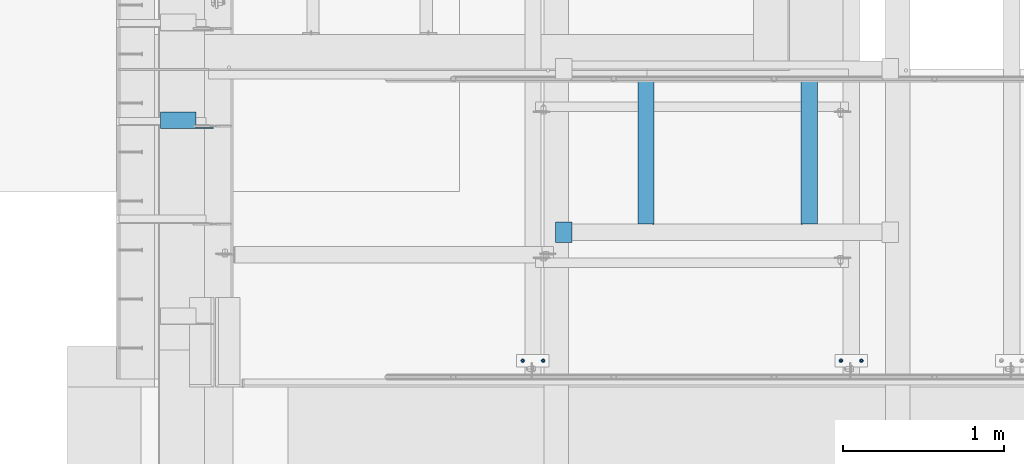
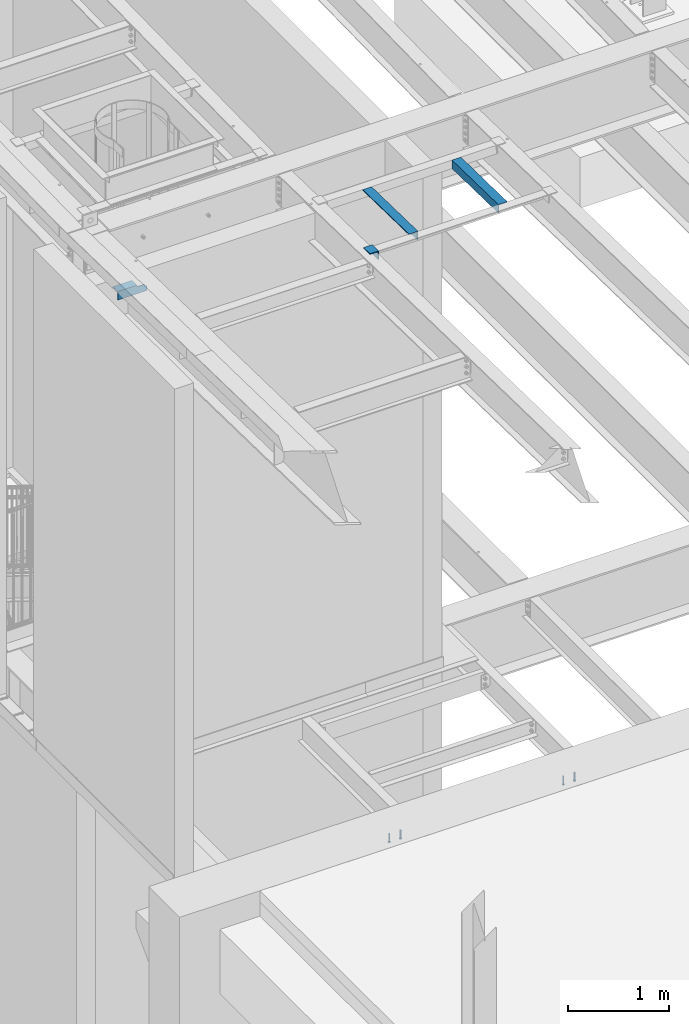
# One storey, part 1249 of 1763: 8 beams, 4 elements without a shape of their own.
"""IFC2X3 building model written with IfcOpenShell, lengths in millimetres."""

from ifc_helpers import new_model, si_unit, frame, origin_with_axes, place, context, subcontext, project, spatial, faceted_brep, material, type_object, element, aggregate, save


model = new_model("IFC2X3")

# Units and contexts
model_context = context("Model", 3, precision=1e-05, world=origin_with_axes())
body_context = subcontext(model_context, "Body", "Model", "MODEL_VIEW")
ifc_project = project(units=[si_unit("LENGTHUNIT", "METRE", prefix="MILLI"), si_unit("AREAUNIT", "SQUARE_METRE"), si_unit("VOLUMEUNIT", "CUBIC_METRE"), si_unit("MASSUNIT", "GRAM", prefix="KILO"), si_unit("TIMEUNIT", "SECOND"), si_unit("PLANEANGLEUNIT", "RADIAN"), si_unit("SOLIDANGLEUNIT", "STERADIAN"), si_unit("THERMODYNAMICTEMPERATUREUNIT", "DEGREE_CELSIUS"), si_unit("LUMINOUSINTENSITYUNIT", "LUMEN")], contexts=[model_context])

# Site, building, storey
site_placement = place(None, origin_with_axes())
site = spatial("IfcSite", under=ifc_project, at=site_placement, CompositionType="ELEMENT")
building_placement = place(site_placement, origin_with_axes())
building = spatial("IfcBuilding", under=site, at=building_placement, Name="Undefined", CompositionType="ELEMENT")
storey_placement = place(building_placement, origin_with_axes())
storey = spatial("IfcBuildingStorey", under=building, at=storey_placement, Name="Undefined", CompositionType="ELEMENT", Elevation=0.0)

# Assembly, beams
assembly_1_placement = place(storey_placement, origin_with_axes())
assembly_1 = element("IfcElementAssembly", 1, at=assembly_1_placement, inside=storey, Name="EMBED PLATE", AssemblyPlace="NOTDEFINED", PredefinedType="RIGID_FRAME")
ifc_material_1 = material(Name="STEEL/A108")
beam_type_1 = type_object("IfcBeamType", PredefinedType="NOTDEFINED")
beam_1_placement = place(assembly_1_placement, frame((-83349.5372767501, 27444.6999954224, 4879.975), z_axis=(1.0, 0.0, 0.0), x_axis=(0.0, 0.0, -1.0)))
beam_1 = element("IfcBeam", 2, at=beam_1_placement, type_object=beam_type_1, material=ifc_material_1, Name="HEADED STUD ANCHOR", context=body_context, shape_type="Brep", body=[
    faceted_brep([(0.0, -3.1800000667572, 5.5), (0.0, -5.5, 3.1800000667572), (94.4880000000003, -5.5, 3.1800000667572), (94.4880000000003, -3.1800000667572, 5.5), (0.0, -6.34999999999491, 1.45519152283669e-11), (94.4880000000003, -6.34999990463257, 0.0), (0.0, -5.5, -3.1800000667572), (94.4880000000003, -5.5, -3.1800000667572), (0.0, -3.1800000667572, -5.5), (94.4880000000003, -3.1800000667572, -5.5), (0.0, 0.0, -6.34999990463257), (94.4880000000003, 0.0, -6.34999990463257), (0.0, 3.1800000667572, -5.5), (94.4880000000003, 3.1800000667572, -5.5), (0.0, 5.5, -3.1800000667572), (94.4880000000003, 5.5, -3.1800000667572), (0.0, 6.34999999999491, -2.91038304567337e-11), (94.4880000000003, 6.34999990463257, 0.0), (0.0, 5.5, 3.1800000667572), (94.4880000000003, 5.5, 3.1800000667572), (0.0, 3.1800000667572, 5.5), (94.4880000000003, 3.1800000667572, 5.5), (0.0, 0.0, 6.34999990463257), (94.4880000000003, 0.0, 6.34999990463257), (96.5200000000004, -10.9899997711182, 6.34999990463257), (96.5200000000004, -6.34000015258789, 10.9899997711182), (96.5200000000004, -12.6999998092651, 0.0), (96.5200000000004, -10.9899997711182, -6.34999990463257), (96.5200000000004, -6.34000015258789, -10.9899997711182), (96.5200000000004, 0.0, -12.6899995803833), (96.5200000000004, 6.34000015258789, -10.9899997711182), (96.5200000000004, 10.9899997711182, -6.34999990463257), (96.5200000000004, 12.6999998092651, 0.0), (96.5200000000004, 10.9899997711182, 6.34999990463257), (96.5200000000004, 6.34000015258789, 10.9899997711182), (96.5200000000004, 0.0, 12.6899995803833), (101.6, -10.9899997711182, 6.34999990463257), (101.6, -6.34000015258789, 10.9899997711182), (101.6, -12.6999998092651, 0.0), (101.6, -10.9899997711182, -6.34999990463257), (101.6, -6.34000015258789, -10.9899997711182), (101.6, 0.0, -12.6899995803833), (101.6, 6.34000015258789, -10.9899997711182), (101.6, 10.9899997711182, -6.34999990463257), (101.6, 12.6999998092651, 0.0), (101.6, 10.9899997711182, 6.34999990463257), (101.6, 6.34000015258789, 10.9899997711182), (101.6, 0.0, 12.6899995803833)], [[[0, 1, 2, 3]], [[1, 4, 5, 2]], [[4, 6, 7, 5]], [[6, 8, 9, 7]], [[8, 10, 11, 9]], [[10, 12, 13, 11]], [[12, 14, 15, 13]], [[14, 16, 17, 15]], [[16, 18, 19, 17]], [[18, 20, 21, 19]], [[20, 22, 23, 21]], [[22, 0, 3, 23]], [[22, 20, 18, 16, 14, 12, 10, 8, 6, 4, 1, 0]], [[3, 2, 24, 25]], [[2, 5, 26, 24]], [[5, 7, 27, 26]], [[7, 9, 28, 27]], [[9, 11, 29, 28]], [[11, 13, 30, 29]], [[13, 15, 31, 30]], [[15, 17, 32, 31]], [[17, 19, 33, 32]], [[19, 21, 34, 33]], [[21, 23, 35, 34]], [[23, 3, 25, 35]], [[25, 24, 36, 37]], [[24, 26, 38, 36]], [[26, 27, 39, 38]], [[27, 28, 40, 39]], [[28, 29, 41, 40]], [[29, 30, 42, 41]], [[30, 31, 43, 42]], [[31, 32, 44, 43]], [[32, 33, 45, 44]], [[33, 34, 46, 45]], [[34, 35, 47, 46]], [[35, 25, 37, 47]], [[38, 39, 40, 41, 42, 43, 44, 45, 46, 47, 37, 36]]]),
])
beam_2_placement = place(assembly_1_placement, frame((-83476.5372736983, 27444.6999954224, 4879.975), z_axis=(1.0, 0.0, 0.0), x_axis=(0.0, 0.0, -1.0)))
beam_2 = element("IfcBeam", 3, at=beam_2_placement, type_object=beam_type_1, material=ifc_material_1, Name="HEADED STUD ANCHOR", context=body_context, shape_type="Brep", body=[
    faceted_brep([(0.0, -3.1800000667572, 5.5), (0.0, -5.5, 3.1800000667572), (94.4880000000003, -5.5, 3.1800000667572), (94.4880000000003, -3.1800000667572, 5.5), (0.0, -6.34999999999491, 1.45519152283669e-11), (94.4880000000003, -6.34999990463257, 0.0), (0.0, -5.5, -3.1800000667572), (94.4880000000003, -5.5, -3.1800000667572), (0.0, -3.1800000667572, -5.5), (94.4880000000003, -3.1800000667572, -5.5), (0.0, 0.0, -6.34999990463257), (94.4880000000003, 0.0, -6.34999990463257), (0.0, 3.1800000667572, -5.5), (94.4880000000003, 3.1800000667572, -5.5), (0.0, 5.5, -3.1800000667572), (94.4880000000003, 5.5, -3.1800000667572), (0.0, 6.34999999999491, -2.91038304567337e-11), (94.4880000000003, 6.34999990463257, 0.0), (0.0, 5.5, 3.1800000667572), (94.4880000000003, 5.5, 3.1800000667572), (0.0, 3.1800000667572, 5.5), (94.4880000000003, 3.1800000667572, 5.5), (0.0, 0.0, 6.34999990463257), (94.4880000000003, 0.0, 6.34999990463257), (96.5200000000004, -10.9899997711182, 6.34999990463257), (96.5200000000004, -6.34000015258789, 10.9899997711182), (96.5200000000004, -12.6999998092651, 0.0), (96.5200000000004, -10.9899997711182, -6.34999990463257), (96.5200000000004, -6.34000015258789, -10.9899997711182), (96.5200000000004, 0.0, -12.6899995803833), (96.5200000000004, 6.34000015258789, -10.9899997711182), (96.5200000000004, 10.9899997711182, -6.34999990463257), (96.5200000000004, 12.6999998092651, 0.0), (96.5200000000004, 10.9899997711182, 6.34999990463257), (96.5200000000004, 6.34000015258789, 10.9899997711182), (96.5200000000004, 0.0, 12.6899995803833), (101.6, -10.9899997711182, 6.34999990463257), (101.6, -6.34000015258789, 10.9899997711182), (101.6, -12.6999998092651, 0.0), (101.6, -10.9899997711182, -6.34999990463257), (101.6, -6.34000015258789, -10.9899997711182), (101.6, 0.0, -12.6899995803833), (101.6, 6.34000015258789, -10.9899997711182), (101.6, 10.9899997711182, -6.34999990463257), (101.6, 12.6999998092651, 0.0), (101.6, 10.9899997711182, 6.34999990463257), (101.6, 6.34000015258789, 10.9899997711182), (101.6, 0.0, 12.6899995803833)], [[[0, 1, 2, 3]], [[1, 4, 5, 2]], [[4, 6, 7, 5]], [[6, 8, 9, 7]], [[8, 10, 11, 9]], [[10, 12, 13, 11]], [[12, 14, 15, 13]], [[14, 16, 17, 15]], [[16, 18, 19, 17]], [[18, 20, 21, 19]], [[20, 22, 23, 21]], [[22, 0, 3, 23]], [[22, 20, 18, 16, 14, 12, 10, 8, 6, 4, 1, 0]], [[3, 2, 24, 25]], [[2, 5, 26, 24]], [[5, 7, 27, 26]], [[7, 9, 28, 27]], [[9, 11, 29, 28]], [[11, 13, 30, 29]], [[13, 15, 31, 30]], [[15, 17, 32, 31]], [[17, 19, 33, 32]], [[19, 21, 34, 33]], [[21, 23, 35, 34]], [[23, 3, 25, 35]], [[25, 24, 36, 37]], [[24, 26, 38, 36]], [[26, 27, 39, 38]], [[27, 28, 40, 39]], [[28, 29, 41, 40]], [[29, 30, 42, 41]], [[30, 31, 43, 42]], [[31, 32, 44, 43]], [[32, 33, 45, 44]], [[33, 34, 46, 45]], [[34, 35, 47, 46]], [[35, 25, 37, 47]], [[38, 39, 40, 41, 42, 43, 44, 45, 46, 47, 37, 36]]]),
])
aggregate(assembly_1, [beam_1, beam_2])

assembly_2_placement = place(storey_placement, origin_with_axes())
assembly_2 = element("IfcElementAssembly", 4, at=assembly_2_placement, inside=storey, Name="EMBED PLATE", AssemblyPlace="NOTDEFINED", PredefinedType="RIGID_FRAME")
beam_3_placement = place(assembly_2_placement, frame((-85330.6576146808, 27444.6999954224, 4879.975), z_axis=(1.0, 0.0, 0.0), x_axis=(0.0, 0.0, -1.0)))
beam_3 = element("IfcBeam", 5, at=beam_3_placement, type_object=beam_type_1, material=ifc_material_1, Name="HEADED STUD ANCHOR", context=body_context, shape_type="Brep", body=[
    faceted_brep([(0.0, -3.1800000667572, 5.5), (0.0, -5.5, 3.1800000667572), (94.4880000000003, -5.5, 3.1800000667572), (94.4880000000003, -3.1800000667572, 5.5), (0.0, -6.34999999999491, 1.45519152283669e-11), (94.4880000000003, -6.34999990463257, 0.0), (0.0, -5.5, -3.1800000667572), (94.4880000000003, -5.5, -3.1800000667572), (0.0, -3.1800000667572, -5.5), (94.4880000000003, -3.1800000667572, -5.5), (0.0, 0.0, -6.34999990463257), (94.4880000000003, 0.0, -6.34999990463257), (0.0, 3.1800000667572, -5.5), (94.4880000000003, 3.1800000667572, -5.5), (0.0, 5.5, -3.1800000667572), (94.4880000000003, 5.5, -3.1800000667572), (0.0, 6.34999999999491, -2.91038304567337e-11), (94.4880000000003, 6.34999990463257, 0.0), (0.0, 5.5, 3.1800000667572), (94.4880000000003, 5.5, 3.1800000667572), (0.0, 3.1800000667572, 5.5), (94.4880000000003, 3.1800000667572, 5.5), (0.0, 0.0, 6.34999990463257), (94.4880000000003, 0.0, 6.34999990463257), (96.5200000000004, -10.9899997711182, 6.34999990463257), (96.5200000000004, -6.34000015258789, 10.9899997711182), (96.5200000000004, -12.6999998092651, 0.0), (96.5200000000004, -10.9899997711182, -6.34999990463257), (96.5200000000004, -6.34000015258789, -10.9899997711182), (96.5200000000004, 0.0, -12.6899995803833), (96.5200000000004, 6.34000015258789, -10.9899997711182), (96.5200000000004, 10.9899997711182, -6.34999990463257), (96.5200000000004, 12.6999998092651, 0.0), (96.5200000000004, 10.9899997711182, 6.34999990463257), (96.5200000000004, 6.34000015258789, 10.9899997711182), (96.5200000000004, 0.0, 12.6899995803833), (101.6, -10.9899997711182, 6.34999990463257), (101.6, -6.34000015258789, 10.9899997711182), (101.6, -12.6999998092651, 0.0), (101.6, -10.9899997711182, -6.34999990463257), (101.6, -6.34000015258789, -10.9899997711182), (101.6, 0.0, -12.6899995803833), (101.6, 6.34000015258789, -10.9899997711182), (101.6, 10.9899997711182, -6.34999990463257), (101.6, 12.6999998092651, 0.0), (101.6, 10.9899997711182, 6.34999990463257), (101.6, 6.34000015258789, 10.9899997711182), (101.6, 0.0, 12.6899995803833)], [[[0, 1, 2, 3]], [[1, 4, 5, 2]], [[4, 6, 7, 5]], [[6, 8, 9, 7]], [[8, 10, 11, 9]], [[10, 12, 13, 11]], [[12, 14, 15, 13]], [[14, 16, 17, 15]], [[16, 18, 19, 17]], [[18, 20, 21, 19]], [[20, 22, 23, 21]], [[22, 0, 3, 23]], [[22, 20, 18, 16, 14, 12, 10, 8, 6, 4, 1, 0]], [[3, 2, 24, 25]], [[2, 5, 26, 24]], [[5, 7, 27, 26]], [[7, 9, 28, 27]], [[9, 11, 29, 28]], [[11, 13, 30, 29]], [[13, 15, 31, 30]], [[15, 17, 32, 31]], [[17, 19, 33, 32]], [[19, 21, 34, 33]], [[21, 23, 35, 34]], [[23, 3, 25, 35]], [[25, 24, 36, 37]], [[24, 26, 38, 36]], [[26, 27, 39, 38]], [[27, 28, 40, 39]], [[28, 29, 41, 40]], [[29, 30, 42, 41]], [[30, 31, 43, 42]], [[31, 32, 44, 43]], [[32, 33, 45, 44]], [[33, 34, 46, 45]], [[34, 35, 47, 46]], [[35, 25, 37, 47]], [[38, 39, 40, 41, 42, 43, 44, 45, 46, 47, 37, 36]]]),
])
beam_4_placement = place(assembly_2_placement, frame((-85457.6576116291, 27444.6999954224, 4879.975), z_axis=(1.0, 0.0, 0.0), x_axis=(0.0, 0.0, -1.0)))
beam_4 = element("IfcBeam", 6, at=beam_4_placement, type_object=beam_type_1, material=ifc_material_1, Name="HEADED STUD ANCHOR", context=body_context, shape_type="Brep", body=[
    faceted_brep([(0.0, -3.1800000667572, 5.5), (0.0, -5.5, 3.1800000667572), (94.4880000000003, -5.5, 3.1800000667572), (94.4880000000003, -3.1800000667572, 5.5), (0.0, -6.34999999999491, 1.45519152283669e-11), (94.4880000000003, -6.34999990463257, 0.0), (0.0, -5.5, -3.1800000667572), (94.4880000000003, -5.5, -3.1800000667572), (0.0, -3.1800000667572, -5.5), (94.4880000000003, -3.1800000667572, -5.5), (0.0, 0.0, -6.34999990463257), (94.4880000000003, 0.0, -6.34999990463257), (0.0, 3.1800000667572, -5.5), (94.4880000000003, 3.1800000667572, -5.5), (0.0, 5.5, -3.1800000667572), (94.4880000000003, 5.5, -3.1800000667572), (0.0, 6.34999999999491, -2.91038304567337e-11), (94.4880000000003, 6.34999990463257, 0.0), (0.0, 5.5, 3.1800000667572), (94.4880000000003, 5.5, 3.1800000667572), (0.0, 3.1800000667572, 5.5), (94.4880000000003, 3.1800000667572, 5.5), (0.0, 0.0, 6.34999990463257), (94.4880000000003, 0.0, 6.34999990463257), (96.5200000000004, -10.9899997711182, 6.34999990463257), (96.5200000000004, -6.34000015258789, 10.9899997711182), (96.5200000000004, -12.6999998092651, 0.0), (96.5200000000004, -10.9899997711182, -6.34999990463257), (96.5200000000004, -6.34000015258789, -10.9899997711182), (96.5200000000004, 0.0, -12.6899995803833), (96.5200000000004, 6.34000015258789, -10.9899997711182), (96.5200000000004, 10.9899997711182, -6.34999990463257), (96.5200000000004, 12.6999998092651, 0.0), (96.5200000000004, 10.9899997711182, 6.34999990463257), (96.5200000000004, 6.34000015258789, 10.9899997711182), (96.5200000000004, 0.0, 12.6899995803833), (101.6, -10.9899997711182, 6.34999990463257), (101.6, -6.34000015258789, 10.9899997711182), (101.6, -12.6999998092651, 0.0), (101.6, -10.9899997711182, -6.34999990463257), (101.6, -6.34000015258789, -10.9899997711182), (101.6, 0.0, -12.6899995803833), (101.6, 6.34000015258789, -10.9899997711182), (101.6, 10.9899997711182, -6.34999990463257), (101.6, 12.6999998092651, 0.0), (101.6, 10.9899997711182, 6.34999990463257), (101.6, 6.34000015258789, 10.9899997711182), (101.6, 0.0, 12.6899995803833)], [[[0, 1, 2, 3]], [[1, 4, 5, 2]], [[4, 6, 7, 5]], [[6, 8, 9, 7]], [[8, 10, 11, 9]], [[10, 12, 13, 11]], [[12, 14, 15, 13]], [[14, 16, 17, 15]], [[16, 18, 19, 17]], [[18, 20, 21, 19]], [[20, 22, 23, 21]], [[22, 0, 3, 23]], [[22, 20, 18, 16, 14, 12, 10, 8, 6, 4, 1, 0]], [[3, 2, 24, 25]], [[2, 5, 26, 24]], [[5, 7, 27, 26]], [[7, 9, 28, 27]], [[9, 11, 29, 28]], [[11, 13, 30, 29]], [[13, 15, 31, 30]], [[15, 17, 32, 31]], [[17, 19, 33, 32]], [[19, 21, 34, 33]], [[21, 23, 35, 34]], [[23, 3, 25, 35]], [[25, 24, 36, 37]], [[24, 26, 38, 36]], [[26, 27, 39, 38]], [[27, 28, 40, 39]], [[28, 29, 41, 40]], [[29, 30, 42, 41]], [[30, 31, 43, 42]], [[31, 32, 44, 43]], [[32, 33, 45, 44]], [[33, 34, 46, 45]], [[34, 35, 47, 46]], [[35, 25, 37, 47]], [[38, 39, 40, 41, 42, 43, 44, 45, 46, 47, 37, 36]]]),
])
aggregate(assembly_2, [beam_3, beam_4])

# Assembly, beam
assembly_3_placement = place(storey_placement, origin_with_axes())
assembly_3 = element("IfcElementAssembly", 7, at=assembly_3_placement, inside=storey, Name="BEAM", AssemblyPlace="NOTDEFINED", PredefinedType="RIGID_FRAME")
ifc_material_2 = material(Name="STEEL/A36")
beam_type_2 = type_object("IfcBeamType", Name="L4X4X1/4", PredefinedType="NOTDEFINED")
beam_5_placement = place(assembly_3_placement, frame((-87711.9872706475, 28940.8245769874, 11262.1009058287), z_axis=(0.0, -0.0208942520060009, -0.999781691287208), x_axis=(1.0, 0.0, 0.0)))
beam_5 = element("IfcBeam", 8, at=beam_5_placement, type_object=beam_type_2, material=ifc_material_2, Name="BRACE", ObjectType="L4X4X1/4", context=body_context, shape_type="Brep", body=[
    faceted_brep([(220.662761923406, 44.4500000001208, -44.4499999999807), (220.662761962012, -50.800000000163, -44.4499999999553), (220.66276795695, -50.800000000163, -50.7999999999502), (220.662767915564, 50.8000000001339, -50.7999999999774), (220.662751535681, 50.8000000001339, -33.3786578752915), (220.662751538272, 44.4500000001208, -33.3786578752897), (299.243730570859, 44.4500000001135, -33.3375021376705), (299.243730570859, 50.8000000001339, -33.3375021376723), (2.11002770811319e-10, -50.8000000000357, -50.799999999952), (1.96450855582952e-10, -50.8000000000338, -44.4499999999534), (-2.18278728425503e-11, 44.4500000000007, -44.450000000048), (-1.81898940354586e-10, 44.4500000000371, 50.7999999999374), (-1.96450855582952e-10, 50.8000000000393, 50.7999999999374), (-3.63797880709171e-11, 50.8000000000011, -50.8000000000538), (330.993731689443, 44.4500000000007, 50.7999999999993), (330.993731689443, 50.7999999999993, 50.7999999999993), (330.993730570859, 44.4500000001281, -1.58750213774329), (330.993746948254, 50.8000000001412, -1.5875021377451)], [[[0, 1, 2, 3, 4, 5]], [[6, 5, 4, 7]], [[8, 9, 10, 11, 12, 13]], [[12, 11, 14, 15]], [[15, 14, 16, 17]], [[17, 16, 6, 7]], [[3, 13, 12, 15, 17, 7, 4]], [[8, 13, 3, 2]], [[9, 8, 2, 1]], [[10, 9, 1, 0]], [[16, 14, 11, 10, 0, 5, 6]]]),
])
aggregate(assembly_3, [beam_5])

# Assembly, beams
assembly_4_placement = place(storey_placement, origin_with_axes())
assembly_4 = element("IfcElementAssembly", 9, at=assembly_4_placement, inside=storey, Name="ANGLE", AssemblyPlace="NOTDEFINED", PredefinedType="RIGID_FRAME")
beam_type_3 = type_object("IfcBeamType", Name="L4X4X3/8", PredefinedType="NOTDEFINED")
beam_6_placement = place(assembly_4_placement, frame((-83674.2944165559, 29208.9382110685, 11256.5034294767), z_axis=(0.0, -0.0209013569953167, -0.999781542776098), x_axis=(0.0, -0.999781542838788, 0.0209013539966307)))
beam_6 = element("IfcBeam", 10, at=beam_6_placement, type_object=beam_type_3, material=ifc_material_2, Name="ANGLE", ObjectType="L4X4X3/8", context=body_context, shape_type="Brep", body=[
    faceted_brep([(-3.63797880709171e-11, 50.8000000000011, -50.8000000000538), (-1.96450855582952e-10, 50.8000000000393, 50.7999999999374), (914.5998009184, 50.8000000000029, 50.8000000005613), (914.599800918462, 50.8000000000029, -50.7999999994208), (0.0, 41.2749999999996, 50.7999999999993), (914.5998009184, 41.2749999999942, 50.8000000005613), (0.0, 41.2749999999996, -41.2750000000015), (914.599800918455, 41.2749999999942, -41.274999999423), (0.0, -50.7999999999993, -41.2750000000015), (914.599800918455, -50.8000000000029, -41.274999999423), (2.11002770811319e-10, -50.8000000000357, -50.799999999952), (914.599800918462, -50.8000000000029, -50.7999999994208)], [[[0, 1, 2, 3]], [[1, 4, 5, 2]], [[4, 6, 7, 5]], [[6, 8, 9, 7]], [[8, 10, 11, 9]], [[10, 0, 3, 11]], [[5, 7, 9, 11, 3, 2]], [[10, 8, 6, 4, 1, 0]]]),
])
beam_7_placement = place(assembly_4_placement, frame((-84690.2944165555, 28294.5382110831, 11275.6198064061), z_axis=(0.0, -0.0209013569953167, -0.999781542776098), x_axis=(0.0, 0.999781542776098, -0.0209013569953182)))
beam_7 = element("IfcBeam", 11, at=beam_7_placement, type_object=beam_type_3, material=ifc_material_2, Name="ANGLE", ObjectType="L4X4X3/8", context=body_context, shape_type="Brep", body=[
    faceted_brep([(-3.63797880709171e-11, 50.8000000000011, -50.8000000000538), (-1.96450855582952e-10, 50.8000000000393, 50.7999999999374), (914.5998009184, 50.8000000000029, 50.8000000005613), (914.599800918462, 50.8000000000029, -50.7999999994208), (0.0, 41.2749999999996, 50.7999999999993), (914.5998009184, 41.2749999999942, 50.8000000005613), (0.0, 41.2749999999996, -41.2750000000015), (914.599800918455, 41.2749999999942, -41.274999999423), (0.0, -50.7999999999993, -41.2750000000015), (914.599800918455, -50.8000000000029, -41.274999999423), (2.11002770811319e-10, -50.8000000000357, -50.799999999952), (914.599800918462, -50.8000000000029, -50.7999999994208)], [[[0, 1, 2, 3]], [[1, 4, 5, 2]], [[4, 6, 7, 5]], [[6, 8, 9, 7]], [[8, 10, 11, 9]], [[10, 0, 3, 11]], [[5, 7, 9, 11, 3, 2]], [[10, 8, 6, 4, 1, 0]]]),
])
beam_8_placement = place(assembly_4_placement, frame((-85201.4694165555, 28180.4590955962, 11287.541141916), z_axis=(0.0, -0.0209829029927569, -0.999779834654609), x_axis=(0.0, 0.999779834654609, -0.0209829029927566)))
beam_8 = element("IfcBeam", 12, at=beam_8_placement, type_object=beam_type_3, material=ifc_material_2, Name="ANGLE", ObjectType="L4X4X3/8", context=body_context, shape_type="Brep", body=[
    faceted_brep([(-3.63797880709171e-11, 50.8000000000011, -50.8000000000538), (-1.96450855582952e-10, 50.8000000000393, 50.7999999999374), (127.0, 50.7999999999993, 50.7999999999993), (127.0, 50.7999999999993, -50.7999999999993), (0.0, 41.2749999999996, 50.7999999999993), (127.0, 41.2749999999996, 50.7999999999993), (0.0, 41.2749999999996, -41.2750000000015), (127.0, 41.2749999999996, -41.2750000000015), (0.0, -50.7999999999993, -41.2750000000015), (127.0, -50.7999999999993, -41.2750000000015), (2.11002770811319e-10, -50.8000000000357, -50.799999999952), (127.0, -50.7999999999993, -50.7999999999993)], [[[0, 1, 2, 3]], [[1, 4, 5, 2]], [[4, 6, 7, 5]], [[6, 8, 9, 7]], [[8, 10, 11, 9]], [[10, 0, 3, 11]], [[5, 7, 9, 11, 3, 2]], [[10, 8, 6, 4, 1, 0]]]),
])
aggregate(assembly_4, [beam_6, beam_7, beam_8])

save(model, "model.ifc")
